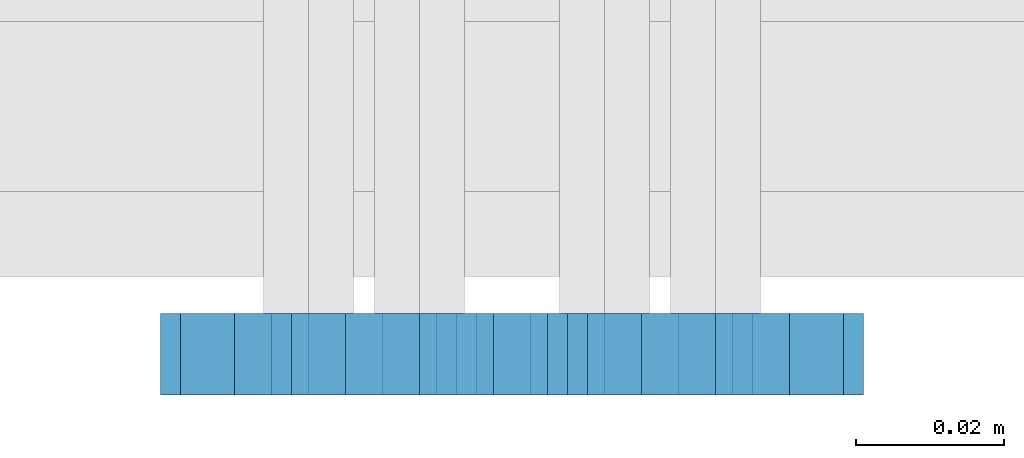
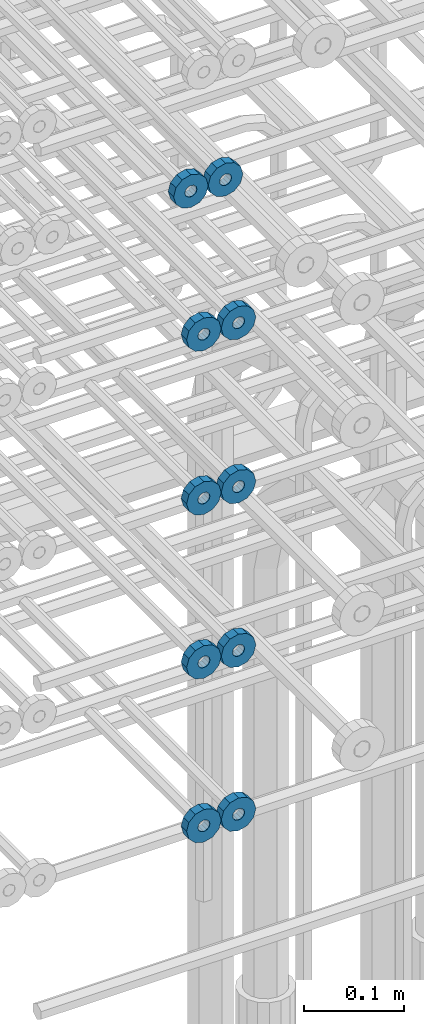
# One storey, part 168 of 177: 10 beams.
"""IFC2X3 building model written with IfcOpenShell, lengths in millimetres."""

from ifc_helpers import new_model, si_unit, frame, origin_with_axes, place, context, subcontext, project, spatial, faceted_brep, material, type_object, element, save


model = new_model("IFC2X3")

# Units and contexts
model_context_1 = context("Model", 3, precision=1e-05, world=origin_with_axes())
model_context_2 = context("Model", 3, precision=1e-05, world=origin_with_axes())
body_context = subcontext(model_context_2, "Body", "Model", "MODEL_VIEW")
ifc_project = project(units=[si_unit("LENGTHUNIT", "METRE", prefix="MILLI"), si_unit("AREAUNIT", "SQUARE_METRE"), si_unit("VOLUMEUNIT", "CUBIC_METRE"), si_unit("MASSUNIT", "GRAM", prefix="KILO"), si_unit("TIMEUNIT", "SECOND"), si_unit("PLANEANGLEUNIT", "RADIAN"), si_unit("SOLIDANGLEUNIT", "STERADIAN"), si_unit("THERMODYNAMICTEMPERATUREUNIT", "DEGREE_CELSIUS"), si_unit("LUMINOUSINTENSITYUNIT", "LUMEN")], contexts=[model_context_1])

# Site, building, storey
site_placement = place(None, origin_with_axes())
site = spatial("IfcSite", under=ifc_project, at=site_placement, CompositionType="ELEMENT")
building_placement = place(site_placement, origin_with_axes())
building = spatial("IfcBuilding", under=site, at=building_placement, Name="Undefined", CompositionType="ELEMENT")
storey_placement = place(building_placement, origin_with_axes())
storey = spatial("IfcBuildingStorey", under=building, at=storey_placement, Name="Undefined", CompositionType="ELEMENT", Elevation=0.0)

# Beams
ifc_material = material(Name="STEEL/Steel_Undefined")
beam_type = type_object("IfcBeamType", PredefinedType="NOTDEFINED")
beam_1_placement = place(storey_placement, frame((2036031.99847313, 6205070.98588033, 21004.9868114202), z_axis=(0.0, 0.0, -1.0), x_axis=(0.0, -1.0, 0.0)))
element("IfcBeam", 1, at=beam_1_placement, inside=storey, type_object=beam_type, material=ifc_material, context=body_context, shape_type="Brep", body=[
    faceted_brep([(-3.63797880709171e-12, -7.0, -2.3283064365387e-10), (-8.62348444298797e-13, -6.06217782649107, 3.5), (10.9999999999964, -6.06217782665044, 3.49999999976717), (10.9999999999964, -7.0, -2.3283064365387e-10), (-3.63797880709171e-12, -3.5, 6.06217782618478), (11.0, -3.5, 6.06217782618478), (-1.72469688859759e-12, 0.0, 7.0), (11.0, 0.0, 6.99999999976717), (-3.63797880709171e-12, 3.5, 6.06217782618478), (11.0, 3.5, 6.06217782618478), (-8.62348444298795e-13, 6.06217782649107, 3.5), (10.9999999999964, 6.06217782665044, 3.49999999976717), (-3.63797880709171e-12, 7.0, -2.3283064365387e-10), (10.9999999999964, 7.0, -2.3283064365387e-10), (8.62348444298797e-13, 6.06217782649107, -3.5), (10.9999999999964, 6.06217782665044, -3.50000000023283), (-3.63797880709171e-12, 3.5, -6.06217782665044), (10.9999999999964, 3.5, -6.06217782665044), (1.72469688859759e-12, -2.72004641033163e-15, -7.0), (10.9999999999964, 0.0, -7.00000000023283), (-3.63797880709171e-12, -3.5, -6.06217782665044), (10.9999999999964, -3.5, -6.06217782665044), (8.62348444298796e-13, -6.06217782649107, -3.5), (10.9999999999964, -6.06217782665044, -3.50000000023283), (0.0, -20.0000000009313, 0.0), (0.0, -17.320508075878, -10.0), (10.9999999999964, -17.320508075878, -10.0000000002328), (10.9999999999964, -20.0, -2.3283064365387e-10), (0.0, -10.0000000009313, -17.3205080756452), (11.0, -10.0, -17.320508075878), (0.0, -1.86264514923096e-09, -19.9999999998836), (10.9999999999964, 0.0, -20.0000000002328), (0.0, 9.99999999906868, -17.3205080755288), (11.0, 10.0, -17.320508075878), (0.0, 17.320508075878, -10.0), (10.9999999999964, 17.320508075878, -10.0000000002328), (0.0, 19.9999999990687, 0.0), (10.9999999999964, 20.0, -2.3283064365387e-10), (0.0, 17.3205080740154, 10.0), (11.0, 17.320508075878, 9.99999999976717), (0.0, 9.99999999906868, 17.3205080757616), (10.9999999999964, 10.0, 17.3205080754124), (0.0, 0.0, 20.0000000001164), (10.9999999999964, 0.0, 19.9999999997672), (0.0, -10.0000000009313, 17.3205080757616), (10.9999999999964, -10.0, 17.3205080754124), (0.0, -17.3205080777407, 10.0000000001164), (11.0, -17.320508075878, 9.99999999976717)], [[[0, 1, 2, 3]], [[1, 4, 5, 2]], [[4, 6, 7, 5]], [[6, 8, 9, 7]], [[8, 10, 11, 9]], [[10, 12, 13, 11]], [[12, 14, 15, 13]], [[14, 16, 17, 15]], [[16, 18, 19, 17]], [[18, 20, 21, 19]], [[20, 22, 23, 21]], [[22, 0, 3, 23]], [[24, 25, 26, 27]], [[25, 28, 29, 26]], [[28, 30, 31, 29]], [[30, 32, 33, 31]], [[32, 34, 35, 33]], [[34, 36, 37, 35]], [[36, 38, 39, 37]], [[38, 40, 41, 39]], [[40, 42, 43, 41]], [[42, 44, 45, 43]], [[44, 46, 47, 45]], [[46, 24, 27, 47]], [[29, 31, 33, 35, 37, 39, 41, 43, 45, 47, 27, 26], [5, 7, 9, 11, 13, 15, 17, 19, 21, 23, 3, 2]], [[46, 44, 42, 40, 38, 36, 34, 32, 30, 28, 25, 24], [22, 20, 18, 16, 14, 12, 10, 8, 6, 4, 1, 0]]]),
])
beam_2_placement = place(storey_placement, frame((2035991.99847313, 6205070.98588033, 21004.9868114202), z_axis=(0.0, 0.0, -1.0), x_axis=(0.0, -1.0, 0.0)))
element("IfcBeam", 2, at=beam_2_placement, inside=storey, type_object=beam_type, material=ifc_material, context=body_context, shape_type="Brep", body=[
    faceted_brep([(-3.63797880709171e-12, -7.0, -2.3283064365387e-10), (-8.62348444298797e-13, -6.06217782649107, 3.5), (10.9999999999964, -6.06217782665044, 3.49999999976717), (10.9999999999964, -7.0, -2.3283064365387e-10), (-3.63797880709171e-12, -3.5, 6.06217782618478), (11.0, -3.5, 6.06217782618478), (-1.72469688859759e-12, 0.0, 7.0), (11.0, 0.0, 6.99999999976717), (-3.63797880709171e-12, 3.5, 6.06217782618478), (11.0, 3.5, 6.06217782618478), (-8.62348444298795e-13, 6.06217782649107, 3.5), (10.9999999999964, 6.06217782665044, 3.49999999976717), (-3.63797880709171e-12, 7.0, -2.3283064365387e-10), (10.9999999999964, 7.0, -2.3283064365387e-10), (8.62348444298797e-13, 6.06217782649107, -3.5), (10.9999999999964, 6.06217782665044, -3.50000000023283), (-3.63797880709171e-12, 3.5, -6.06217782665044), (10.9999999999964, 3.5, -6.06217782665044), (1.72469688859759e-12, -2.72004641033163e-15, -7.0), (10.9999999999964, 0.0, -7.00000000023283), (-3.63797880709171e-12, -3.5, -6.06217782665044), (10.9999999999964, -3.5, -6.06217782665044), (8.62348444298796e-13, -6.06217782649107, -3.5), (10.9999999999964, -6.06217782665044, -3.50000000023283), (0.0, -20.0000000009313, 0.0), (0.0, -17.320508075878, -10.0), (10.9999999999964, -17.320508075878, -10.0000000002328), (10.9999999999964, -20.0, -2.3283064365387e-10), (0.0, -10.0000000009313, -17.3205080756452), (11.0, -10.0, -17.320508075878), (0.0, -1.86264514923096e-09, -19.9999999998836), (10.9999999999964, 0.0, -20.0000000002328), (0.0, 9.99999999906868, -17.3205080755288), (11.0, 10.0, -17.320508075878), (0.0, 17.320508075878, -10.0), (10.9999999999964, 17.320508075878, -10.0000000002328), (0.0, 19.9999999990687, 0.0), (10.9999999999964, 20.0, -2.3283064365387e-10), (0.0, 17.3205080740154, 10.0), (11.0, 17.320508075878, 9.99999999976717), (0.0, 9.99999999906868, 17.3205080757616), (10.9999999999964, 10.0, 17.3205080754124), (0.0, 0.0, 20.0000000001164), (10.9999999999964, 0.0, 19.9999999997672), (0.0, -10.0000000009313, 17.3205080757616), (10.9999999999964, -10.0, 17.3205080754124), (0.0, -17.3205080777407, 10.0000000001164), (11.0, -17.320508075878, 9.99999999976717)], [[[0, 1, 2, 3]], [[1, 4, 5, 2]], [[4, 6, 7, 5]], [[6, 8, 9, 7]], [[8, 10, 11, 9]], [[10, 12, 13, 11]], [[12, 14, 15, 13]], [[14, 16, 17, 15]], [[16, 18, 19, 17]], [[18, 20, 21, 19]], [[20, 22, 23, 21]], [[22, 0, 3, 23]], [[24, 25, 26, 27]], [[25, 28, 29, 26]], [[28, 30, 31, 29]], [[30, 32, 33, 31]], [[32, 34, 35, 33]], [[34, 36, 37, 35]], [[36, 38, 39, 37]], [[38, 40, 41, 39]], [[40, 42, 43, 41]], [[42, 44, 45, 43]], [[44, 46, 47, 45]], [[46, 24, 27, 47]], [[29, 31, 33, 35, 37, 39, 41, 43, 45, 47, 27, 26], [5, 7, 9, 11, 13, 15, 17, 19, 21, 23, 3, 2]], [[46, 44, 42, 40, 38, 36, 34, 32, 30, 28, 25, 24], [22, 20, 18, 16, 14, 12, 10, 8, 6, 4, 1, 0]]]),
])
beam_3_placement = place(storey_placement, frame((2036046.99847313, 6205070.98588033, 20824.9868114254), z_axis=(0.0, 0.0, -1.0), x_axis=(0.0, -1.0, 0.0)))
element("IfcBeam", 3, at=beam_3_placement, inside=storey, type_object=beam_type, material=ifc_material, context=body_context, shape_type="Brep", body=[
    faceted_brep([(-3.63797880709171e-12, -7.0, -2.3283064365387e-10), (-8.62348444298797e-13, -6.06217782649107, 3.5), (10.9999999999964, -6.06217782665044, 3.49999999976717), (10.9999999999964, -7.0, -2.3283064365387e-10), (-3.63797880709171e-12, -3.5, 6.06217782618478), (11.0, -3.5, 6.06217782618478), (-1.72469688859759e-12, 0.0, 7.0), (11.0, 0.0, 6.99999999976717), (-3.63797880709171e-12, 3.5, 6.06217782618478), (11.0, 3.5, 6.06217782618478), (-8.62348444298795e-13, 6.06217782649107, 3.5), (10.9999999999964, 6.06217782665044, 3.49999999976717), (-3.63797880709171e-12, 7.0, -2.3283064365387e-10), (10.9999999999964, 7.0, -2.3283064365387e-10), (8.62348444298797e-13, 6.06217782649107, -3.5), (10.9999999999964, 6.06217782665044, -3.50000000023283), (-3.63797880709171e-12, 3.5, -6.06217782665044), (10.9999999999964, 3.5, -6.06217782665044), (1.72469688859759e-12, -2.72004641033163e-15, -7.0), (10.9999999999964, 0.0, -7.00000000023283), (-3.63797880709171e-12, -3.5, -6.06217782665044), (10.9999999999964, -3.5, -6.06217782665044), (8.62348444298796e-13, -6.06217782649107, -3.5), (10.9999999999964, -6.06217782665044, -3.50000000023283), (0.0, -20.0000000009313, 0.0), (0.0, -17.320508075878, -10.0), (10.9999999999964, -17.320508075878, -10.0000000002328), (10.9999999999964, -20.0, -2.3283064365387e-10), (0.0, -10.0000000009313, -17.3205080756452), (11.0, -10.0, -17.320508075878), (0.0, -1.86264514923096e-09, -19.9999999998836), (10.9999999999964, 0.0, -20.0000000002328), (0.0, 9.99999999906868, -17.3205080755288), (11.0, 10.0, -17.320508075878), (0.0, 17.320508075878, -10.0), (10.9999999999964, 17.320508075878, -10.0000000002328), (0.0, 19.9999999990687, 0.0), (10.9999999999964, 20.0, -2.3283064365387e-10), (0.0, 17.3205080740154, 10.0), (11.0, 17.320508075878, 9.99999999976717), (0.0, 9.99999999906868, 17.3205080757616), (10.9999999999964, 10.0, 17.3205080754124), (0.0, 0.0, 20.0000000001164), (10.9999999999964, 0.0, 19.9999999997672), (0.0, -10.0000000009313, 17.3205080757616), (10.9999999999964, -10.0, 17.3205080754124), (0.0, -17.3205080777407, 10.0000000001164), (11.0, -17.320508075878, 9.99999999976717)], [[[0, 1, 2, 3]], [[1, 4, 5, 2]], [[4, 6, 7, 5]], [[6, 8, 9, 7]], [[8, 10, 11, 9]], [[10, 12, 13, 11]], [[12, 14, 15, 13]], [[14, 16, 17, 15]], [[16, 18, 19, 17]], [[18, 20, 21, 19]], [[20, 22, 23, 21]], [[22, 0, 3, 23]], [[24, 25, 26, 27]], [[25, 28, 29, 26]], [[28, 30, 31, 29]], [[30, 32, 33, 31]], [[32, 34, 35, 33]], [[34, 36, 37, 35]], [[36, 38, 39, 37]], [[38, 40, 41, 39]], [[40, 42, 43, 41]], [[42, 44, 45, 43]], [[44, 46, 47, 45]], [[46, 24, 27, 47]], [[29, 31, 33, 35, 37, 39, 41, 43, 45, 47, 27, 26], [5, 7, 9, 11, 13, 15, 17, 19, 21, 23, 3, 2]], [[46, 44, 42, 40, 38, 36, 34, 32, 30, 28, 25, 24], [22, 20, 18, 16, 14, 12, 10, 8, 6, 4, 1, 0]]]),
])
beam_4_placement = place(storey_placement, frame((2036006.99847313, 6205070.98588033, 20824.9868114254), z_axis=(0.0, 0.0, -1.0), x_axis=(0.0, -1.0, 0.0)))
element("IfcBeam", 4, at=beam_4_placement, inside=storey, type_object=beam_type, material=ifc_material, context=body_context, shape_type="Brep", body=[
    faceted_brep([(-3.63797880709171e-12, -7.0, -2.3283064365387e-10), (-8.62348444298797e-13, -6.06217782649107, 3.5), (10.9999999999964, -6.06217782665044, 3.49999999976717), (10.9999999999964, -7.0, -2.3283064365387e-10), (-3.63797880709171e-12, -3.5, 6.06217782618478), (11.0, -3.5, 6.06217782618478), (-1.72469688859759e-12, 0.0, 7.0), (11.0, 0.0, 6.99999999976717), (-3.63797880709171e-12, 3.5, 6.06217782618478), (11.0, 3.5, 6.06217782618478), (-8.62348444298795e-13, 6.06217782649107, 3.5), (10.9999999999964, 6.06217782665044, 3.49999999976717), (-3.63797880709171e-12, 7.0, -2.3283064365387e-10), (10.9999999999964, 7.0, -2.3283064365387e-10), (8.62348444298797e-13, 6.06217782649107, -3.5), (10.9999999999964, 6.06217782665044, -3.50000000023283), (-3.63797880709171e-12, 3.5, -6.06217782665044), (10.9999999999964, 3.5, -6.06217782665044), (1.72469688859759e-12, -2.72004641033163e-15, -7.0), (10.9999999999964, 0.0, -7.00000000023283), (-3.63797880709171e-12, -3.5, -6.06217782665044), (10.9999999999964, -3.5, -6.06217782665044), (8.62348444298796e-13, -6.06217782649107, -3.5), (10.9999999999964, -6.06217782665044, -3.50000000023283), (0.0, -20.0000000009313, 0.0), (0.0, -17.320508075878, -10.0), (10.9999999999964, -17.320508075878, -10.0000000002328), (10.9999999999964, -20.0, -2.3283064365387e-10), (0.0, -10.0000000009313, -17.3205080756452), (11.0, -10.0, -17.320508075878), (0.0, -1.86264514923096e-09, -19.9999999998836), (10.9999999999964, 0.0, -20.0000000002328), (0.0, 9.99999999906868, -17.3205080755288), (11.0, 10.0, -17.320508075878), (0.0, 17.320508075878, -10.0), (10.9999999999964, 17.320508075878, -10.0000000002328), (0.0, 19.9999999990687, 0.0), (10.9999999999964, 20.0, -2.3283064365387e-10), (0.0, 17.3205080740154, 10.0), (11.0, 17.320508075878, 9.99999999976717), (0.0, 9.99999999906868, 17.3205080757616), (10.9999999999964, 10.0, 17.3205080754124), (0.0, 0.0, 20.0000000001164), (10.9999999999964, 0.0, 19.9999999997672), (0.0, -10.0000000009313, 17.3205080757616), (10.9999999999964, -10.0, 17.3205080754124), (0.0, -17.3205080777407, 10.0000000001164), (11.0, -17.320508075878, 9.99999999976717)], [[[0, 1, 2, 3]], [[1, 4, 5, 2]], [[4, 6, 7, 5]], [[6, 8, 9, 7]], [[8, 10, 11, 9]], [[10, 12, 13, 11]], [[12, 14, 15, 13]], [[14, 16, 17, 15]], [[16, 18, 19, 17]], [[18, 20, 21, 19]], [[20, 22, 23, 21]], [[22, 0, 3, 23]], [[24, 25, 26, 27]], [[25, 28, 29, 26]], [[28, 30, 31, 29]], [[30, 32, 33, 31]], [[32, 34, 35, 33]], [[34, 36, 37, 35]], [[36, 38, 39, 37]], [[38, 40, 41, 39]], [[40, 42, 43, 41]], [[42, 44, 45, 43]], [[44, 46, 47, 45]], [[46, 24, 27, 47]], [[29, 31, 33, 35, 37, 39, 41, 43, 45, 47, 27, 26], [5, 7, 9, 11, 13, 15, 17, 19, 21, 23, 3, 2]], [[46, 44, 42, 40, 38, 36, 34, 32, 30, 28, 25, 24], [22, 20, 18, 16, 14, 12, 10, 8, 6, 4, 1, 0]]]),
])
beam_5_placement = place(storey_placement, frame((2036046.99847313, 6205070.98588033, 20624.9868114254), z_axis=(0.0, 0.0, -1.0), x_axis=(0.0, -1.0, 0.0)))
element("IfcBeam", 5, at=beam_5_placement, inside=storey, type_object=beam_type, material=ifc_material, context=body_context, shape_type="Brep", body=[
    faceted_brep([(-3.63797880709171e-12, -7.0, -2.3283064365387e-10), (-8.62348444298797e-13, -6.06217782649107, 3.5), (10.9999999999964, -6.06217782665044, 3.49999999976717), (10.9999999999964, -7.0, -2.3283064365387e-10), (-3.63797880709171e-12, -3.5, 6.06217782618478), (11.0, -3.5, 6.06217782618478), (-1.72469688859759e-12, 0.0, 7.0), (11.0, 0.0, 6.99999999976717), (-3.63797880709171e-12, 3.5, 6.06217782618478), (11.0, 3.5, 6.06217782618478), (-8.62348444298795e-13, 6.06217782649107, 3.5), (10.9999999999964, 6.06217782665044, 3.49999999976717), (-3.63797880709171e-12, 7.0, -2.3283064365387e-10), (10.9999999999964, 7.0, -2.3283064365387e-10), (8.62348444298797e-13, 6.06217782649107, -3.5), (10.9999999999964, 6.06217782665044, -3.50000000023283), (-3.63797880709171e-12, 3.5, -6.06217782665044), (10.9999999999964, 3.5, -6.06217782665044), (1.72469688859759e-12, -2.72004641033163e-15, -7.0), (10.9999999999964, 0.0, -7.00000000023283), (-3.63797880709171e-12, -3.5, -6.06217782665044), (10.9999999999964, -3.5, -6.06217782665044), (8.62348444298796e-13, -6.06217782649107, -3.5), (10.9999999999964, -6.06217782665044, -3.50000000023283), (0.0, -20.0000000009313, 0.0), (0.0, -17.320508075878, -10.0), (10.9999999999964, -17.320508075878, -10.0000000002328), (10.9999999999964, -20.0, -2.3283064365387e-10), (0.0, -10.0000000009313, -17.3205080756452), (11.0, -10.0, -17.320508075878), (0.0, -1.86264514923096e-09, -19.9999999998836), (10.9999999999964, 0.0, -20.0000000002328), (0.0, 9.99999999906868, -17.3205080755288), (11.0, 10.0, -17.320508075878), (0.0, 17.320508075878, -10.0), (10.9999999999964, 17.320508075878, -10.0000000002328), (0.0, 19.9999999990687, 0.0), (10.9999999999964, 20.0, -2.3283064365387e-10), (0.0, 17.3205080740154, 10.0), (11.0, 17.320508075878, 9.99999999976717), (0.0, 9.99999999906868, 17.3205080757616), (10.9999999999964, 10.0, 17.3205080754124), (0.0, 0.0, 20.0000000001164), (10.9999999999964, 0.0, 19.9999999997672), (0.0, -10.0000000009313, 17.3205080757616), (10.9999999999964, -10.0, 17.3205080754124), (0.0, -17.3205080777407, 10.0000000001164), (11.0, -17.320508075878, 9.99999999976717)], [[[0, 1, 2, 3]], [[1, 4, 5, 2]], [[4, 6, 7, 5]], [[6, 8, 9, 7]], [[8, 10, 11, 9]], [[10, 12, 13, 11]], [[12, 14, 15, 13]], [[14, 16, 17, 15]], [[16, 18, 19, 17]], [[18, 20, 21, 19]], [[20, 22, 23, 21]], [[22, 0, 3, 23]], [[24, 25, 26, 27]], [[25, 28, 29, 26]], [[28, 30, 31, 29]], [[30, 32, 33, 31]], [[32, 34, 35, 33]], [[34, 36, 37, 35]], [[36, 38, 39, 37]], [[38, 40, 41, 39]], [[40, 42, 43, 41]], [[42, 44, 45, 43]], [[44, 46, 47, 45]], [[46, 24, 27, 47]], [[29, 31, 33, 35, 37, 39, 41, 43, 45, 47, 27, 26], [5, 7, 9, 11, 13, 15, 17, 19, 21, 23, 3, 2]], [[46, 44, 42, 40, 38, 36, 34, 32, 30, 28, 25, 24], [22, 20, 18, 16, 14, 12, 10, 8, 6, 4, 1, 0]]]),
])
beam_6_placement = place(storey_placement, frame((2036006.99847313, 6205070.98588033, 20624.9868114254), z_axis=(0.0, 0.0, -1.0), x_axis=(0.0, -1.0, 0.0)))
element("IfcBeam", 6, at=beam_6_placement, inside=storey, type_object=beam_type, material=ifc_material, context=body_context, shape_type="Brep", body=[
    faceted_brep([(-3.63797880709171e-12, -7.0, -2.3283064365387e-10), (-8.62348444298797e-13, -6.06217782649107, 3.5), (10.9999999999964, -6.06217782665044, 3.49999999976717), (10.9999999999964, -7.0, -2.3283064365387e-10), (-3.63797880709171e-12, -3.5, 6.06217782618478), (11.0, -3.5, 6.06217782618478), (-1.72469688859759e-12, 0.0, 7.0), (11.0, 0.0, 6.99999999976717), (-3.63797880709171e-12, 3.5, 6.06217782618478), (11.0, 3.5, 6.06217782618478), (-8.62348444298795e-13, 6.06217782649107, 3.5), (10.9999999999964, 6.06217782665044, 3.49999999976717), (-3.63797880709171e-12, 7.0, -2.3283064365387e-10), (10.9999999999964, 7.0, -2.3283064365387e-10), (8.62348444298797e-13, 6.06217782649107, -3.5), (10.9999999999964, 6.06217782665044, -3.50000000023283), (-3.63797880709171e-12, 3.5, -6.06217782665044), (10.9999999999964, 3.5, -6.06217782665044), (1.72469688859759e-12, -2.72004641033163e-15, -7.0), (10.9999999999964, 0.0, -7.00000000023283), (-3.63797880709171e-12, -3.5, -6.06217782665044), (10.9999999999964, -3.5, -6.06217782665044), (8.62348444298796e-13, -6.06217782649107, -3.5), (10.9999999999964, -6.06217782665044, -3.50000000023283), (0.0, -20.0000000009313, 0.0), (0.0, -17.320508075878, -10.0), (10.9999999999964, -17.320508075878, -10.0000000002328), (10.9999999999964, -20.0, -2.3283064365387e-10), (0.0, -10.0000000009313, -17.3205080756452), (11.0, -10.0, -17.320508075878), (0.0, -1.86264514923096e-09, -19.9999999998836), (10.9999999999964, 0.0, -20.0000000002328), (0.0, 9.99999999906868, -17.3205080755288), (11.0, 10.0, -17.320508075878), (0.0, 17.320508075878, -10.0), (10.9999999999964, 17.320508075878, -10.0000000002328), (0.0, 19.9999999990687, 0.0), (10.9999999999964, 20.0, -2.3283064365387e-10), (0.0, 17.3205080740154, 10.0), (11.0, 17.320508075878, 9.99999999976717), (0.0, 9.99999999906868, 17.3205080757616), (10.9999999999964, 10.0, 17.3205080754124), (0.0, 0.0, 20.0000000001164), (10.9999999999964, 0.0, 19.9999999997672), (0.0, -10.0000000009313, 17.3205080757616), (10.9999999999964, -10.0, 17.3205080754124), (0.0, -17.3205080777407, 10.0000000001164), (11.0, -17.320508075878, 9.99999999976717)], [[[0, 1, 2, 3]], [[1, 4, 5, 2]], [[4, 6, 7, 5]], [[6, 8, 9, 7]], [[8, 10, 11, 9]], [[10, 12, 13, 11]], [[12, 14, 15, 13]], [[14, 16, 17, 15]], [[16, 18, 19, 17]], [[18, 20, 21, 19]], [[20, 22, 23, 21]], [[22, 0, 3, 23]], [[24, 25, 26, 27]], [[25, 28, 29, 26]], [[28, 30, 31, 29]], [[30, 32, 33, 31]], [[32, 34, 35, 33]], [[34, 36, 37, 35]], [[36, 38, 39, 37]], [[38, 40, 41, 39]], [[40, 42, 43, 41]], [[42, 44, 45, 43]], [[44, 46, 47, 45]], [[46, 24, 27, 47]], [[29, 31, 33, 35, 37, 39, 41, 43, 45, 47, 27, 26], [5, 7, 9, 11, 13, 15, 17, 19, 21, 23, 3, 2]], [[46, 44, 42, 40, 38, 36, 34, 32, 30, 28, 25, 24], [22, 20, 18, 16, 14, 12, 10, 8, 6, 4, 1, 0]]]),
])
beam_7_placement = place(storey_placement, frame((2036046.99847313, 6205070.98588034, 20424.9868114254), z_axis=(0.0, 0.0, -1.0), x_axis=(0.0, -1.0, 0.0)))
element("IfcBeam", 7, at=beam_7_placement, inside=storey, type_object=beam_type, material=ifc_material, context=body_context, shape_type="Brep", body=[
    faceted_brep([(-3.63797880709171e-12, -7.0, -2.3283064365387e-10), (-8.62348444298797e-13, -6.06217782649107, 3.5), (10.9999999999964, -6.06217782665044, 3.49999999976717), (10.9999999999964, -7.0, -2.3283064365387e-10), (-3.63797880709171e-12, -3.5, 6.06217782618478), (11.0, -3.5, 6.06217782618478), (-1.72469688859759e-12, 0.0, 7.0), (11.0, 0.0, 6.99999999976717), (-3.63797880709171e-12, 3.5, 6.06217782618478), (11.0, 3.5, 6.06217782618478), (-8.62348444298795e-13, 6.06217782649107, 3.5), (10.9999999999964, 6.06217782665044, 3.49999999976717), (-3.63797880709171e-12, 7.0, -2.3283064365387e-10), (10.9999999999964, 7.0, -2.3283064365387e-10), (8.62348444298797e-13, 6.06217782649107, -3.5), (10.9999999999964, 6.06217782665044, -3.50000000023283), (-3.63797880709171e-12, 3.5, -6.06217782665044), (10.9999999999964, 3.5, -6.06217782665044), (1.72469688859759e-12, -2.72004641033163e-15, -7.0), (10.9999999999964, 0.0, -7.00000000023283), (-3.63797880709171e-12, -3.5, -6.06217782665044), (10.9999999999964, -3.5, -6.06217782665044), (8.62348444298796e-13, -6.06217782649107, -3.5), (10.9999999999964, -6.06217782665044, -3.50000000023283), (0.0, -20.0000000009313, 0.0), (0.0, -17.320508075878, -10.0), (10.9999999999964, -17.320508075878, -10.0000000002328), (10.9999999999964, -20.0, -2.3283064365387e-10), (0.0, -10.0000000009313, -17.3205080756452), (11.0, -10.0, -17.320508075878), (0.0, -1.86264514923096e-09, -19.9999999998836), (10.9999999999964, 0.0, -20.0000000002328), (0.0, 9.99999999906868, -17.3205080755288), (11.0, 10.0, -17.320508075878), (0.0, 17.320508075878, -10.0), (10.9999999999964, 17.320508075878, -10.0000000002328), (0.0, 19.9999999990687, 0.0), (10.9999999999964, 20.0, -2.3283064365387e-10), (0.0, 17.3205080740154, 10.0), (11.0, 17.320508075878, 9.99999999976717), (0.0, 9.99999999906868, 17.3205080757616), (10.9999999999964, 10.0, 17.3205080754124), (0.0, 0.0, 20.0000000001164), (10.9999999999964, 0.0, 19.9999999997672), (0.0, -10.0000000009313, 17.3205080757616), (10.9999999999964, -10.0, 17.3205080754124), (0.0, -17.3205080777407, 10.0000000001164), (11.0, -17.320508075878, 9.99999999976717)], [[[0, 1, 2, 3]], [[1, 4, 5, 2]], [[4, 6, 7, 5]], [[6, 8, 9, 7]], [[8, 10, 11, 9]], [[10, 12, 13, 11]], [[12, 14, 15, 13]], [[14, 16, 17, 15]], [[16, 18, 19, 17]], [[18, 20, 21, 19]], [[20, 22, 23, 21]], [[22, 0, 3, 23]], [[24, 25, 26, 27]], [[25, 28, 29, 26]], [[28, 30, 31, 29]], [[30, 32, 33, 31]], [[32, 34, 35, 33]], [[34, 36, 37, 35]], [[36, 38, 39, 37]], [[38, 40, 41, 39]], [[40, 42, 43, 41]], [[42, 44, 45, 43]], [[44, 46, 47, 45]], [[46, 24, 27, 47]], [[29, 31, 33, 35, 37, 39, 41, 43, 45, 47, 27, 26], [5, 7, 9, 11, 13, 15, 17, 19, 21, 23, 3, 2]], [[46, 44, 42, 40, 38, 36, 34, 32, 30, 28, 25, 24], [22, 20, 18, 16, 14, 12, 10, 8, 6, 4, 1, 0]]]),
])
beam_8_placement = place(storey_placement, frame((2036006.99847313, 6205070.98588034, 20424.9868114254), z_axis=(0.0, 0.0, -1.0), x_axis=(0.0, -1.0, 0.0)))
element("IfcBeam", 8, at=beam_8_placement, inside=storey, type_object=beam_type, material=ifc_material, context=body_context, shape_type="Brep", body=[
    faceted_brep([(-3.63797880709171e-12, -7.0, -2.3283064365387e-10), (-8.62348444298797e-13, -6.06217782649107, 3.5), (10.9999999999964, -6.06217782665044, 3.49999999976717), (10.9999999999964, -7.0, -2.3283064365387e-10), (-3.63797880709171e-12, -3.5, 6.06217782618478), (11.0, -3.5, 6.06217782618478), (-1.72469688859759e-12, 0.0, 7.0), (11.0, 0.0, 6.99999999976717), (-3.63797880709171e-12, 3.5, 6.06217782618478), (11.0, 3.5, 6.06217782618478), (-8.62348444298795e-13, 6.06217782649107, 3.5), (10.9999999999964, 6.06217782665044, 3.49999999976717), (-3.63797880709171e-12, 7.0, -2.3283064365387e-10), (10.9999999999964, 7.0, -2.3283064365387e-10), (8.62348444298797e-13, 6.06217782649107, -3.5), (10.9999999999964, 6.06217782665044, -3.50000000023283), (-3.63797880709171e-12, 3.5, -6.06217782665044), (10.9999999999964, 3.5, -6.06217782665044), (1.72469688859759e-12, -2.72004641033163e-15, -7.0), (10.9999999999964, 0.0, -7.00000000023283), (-3.63797880709171e-12, -3.5, -6.06217782665044), (10.9999999999964, -3.5, -6.06217782665044), (8.62348444298796e-13, -6.06217782649107, -3.5), (10.9999999999964, -6.06217782665044, -3.50000000023283), (0.0, -20.0000000009313, 0.0), (0.0, -17.320508075878, -10.0), (10.9999999999964, -17.320508075878, -10.0000000002328), (10.9999999999964, -20.0, -2.3283064365387e-10), (0.0, -10.0000000009313, -17.3205080756452), (11.0, -10.0, -17.320508075878), (0.0, -1.86264514923096e-09, -19.9999999998836), (10.9999999999964, 0.0, -20.0000000002328), (0.0, 9.99999999906868, -17.3205080755288), (11.0, 10.0, -17.320508075878), (0.0, 17.320508075878, -10.0), (10.9999999999964, 17.320508075878, -10.0000000002328), (0.0, 19.9999999990687, 0.0), (10.9999999999964, 20.0, -2.3283064365387e-10), (0.0, 17.3205080740154, 10.0), (11.0, 17.320508075878, 9.99999999976717), (0.0, 9.99999999906868, 17.3205080757616), (10.9999999999964, 10.0, 17.3205080754124), (0.0, 0.0, 20.0000000001164), (10.9999999999964, 0.0, 19.9999999997672), (0.0, -10.0000000009313, 17.3205080757616), (10.9999999999964, -10.0, 17.3205080754124), (0.0, -17.3205080777407, 10.0000000001164), (11.0, -17.320508075878, 9.99999999976717)], [[[0, 1, 2, 3]], [[1, 4, 5, 2]], [[4, 6, 7, 5]], [[6, 8, 9, 7]], [[8, 10, 11, 9]], [[10, 12, 13, 11]], [[12, 14, 15, 13]], [[14, 16, 17, 15]], [[16, 18, 19, 17]], [[18, 20, 21, 19]], [[20, 22, 23, 21]], [[22, 0, 3, 23]], [[24, 25, 26, 27]], [[25, 28, 29, 26]], [[28, 30, 31, 29]], [[30, 32, 33, 31]], [[32, 34, 35, 33]], [[34, 36, 37, 35]], [[36, 38, 39, 37]], [[38, 40, 41, 39]], [[40, 42, 43, 41]], [[42, 44, 45, 43]], [[44, 46, 47, 45]], [[46, 24, 27, 47]], [[29, 31, 33, 35, 37, 39, 41, 43, 45, 47, 27, 26], [5, 7, 9, 11, 13, 15, 17, 19, 21, 23, 3, 2]], [[46, 44, 42, 40, 38, 36, 34, 32, 30, 28, 25, 24], [22, 20, 18, 16, 14, 12, 10, 8, 6, 4, 1, 0]]]),
])
beam_9_placement = place(storey_placement, frame((2036006.99847313, 6205070.98588034, 20224.9868114254), z_axis=(0.0, 0.0, -1.0), x_axis=(0.0, -1.0, 0.0)))
element("IfcBeam", 9, at=beam_9_placement, inside=storey, type_object=beam_type, material=ifc_material, context=body_context, shape_type="Brep", body=[
    faceted_brep([(-3.63797880709171e-12, -7.0, -2.3283064365387e-10), (-8.62348444298797e-13, -6.06217782649107, 3.5), (10.9999999999964, -6.06217782665044, 3.49999999976717), (10.9999999999964, -7.0, -2.3283064365387e-10), (-3.63797880709171e-12, -3.5, 6.06217782618478), (11.0, -3.5, 6.06217782618478), (-1.72469688859759e-12, 0.0, 7.0), (11.0, 0.0, 6.99999999976717), (-3.63797880709171e-12, 3.5, 6.06217782618478), (11.0, 3.5, 6.06217782618478), (-8.62348444298795e-13, 6.06217782649107, 3.5), (10.9999999999964, 6.06217782665044, 3.49999999976717), (-3.63797880709171e-12, 7.0, -2.3283064365387e-10), (10.9999999999964, 7.0, -2.3283064365387e-10), (8.62348444298797e-13, 6.06217782649107, -3.5), (10.9999999999964, 6.06217782665044, -3.50000000023283), (-3.63797880709171e-12, 3.5, -6.06217782665044), (10.9999999999964, 3.5, -6.06217782665044), (1.72469688859759e-12, -2.72004641033163e-15, -7.0), (10.9999999999964, 0.0, -7.00000000023283), (-3.63797880709171e-12, -3.5, -6.06217782665044), (10.9999999999964, -3.5, -6.06217782665044), (8.62348444298796e-13, -6.06217782649107, -3.5), (10.9999999999964, -6.06217782665044, -3.50000000023283), (0.0, -20.0000000009313, 0.0), (0.0, -17.320508075878, -10.0), (10.9999999999964, -17.320508075878, -10.0000000002328), (10.9999999999964, -20.0, -2.3283064365387e-10), (0.0, -10.0000000009313, -17.3205080756452), (11.0, -10.0, -17.320508075878), (0.0, -1.86264514923096e-09, -19.9999999998836), (10.9999999999964, 0.0, -20.0000000002328), (0.0, 9.99999999906868, -17.3205080755288), (11.0, 10.0, -17.320508075878), (0.0, 17.320508075878, -10.0), (10.9999999999964, 17.320508075878, -10.0000000002328), (0.0, 19.9999999990687, 0.0), (10.9999999999964, 20.0, -2.3283064365387e-10), (0.0, 17.3205080740154, 10.0), (11.0, 17.320508075878, 9.99999999976717), (0.0, 9.99999999906868, 17.3205080757616), (10.9999999999964, 10.0, 17.3205080754124), (0.0, 0.0, 20.0000000001164), (10.9999999999964, 0.0, 19.9999999997672), (0.0, -10.0000000009313, 17.3205080757616), (10.9999999999964, -10.0, 17.3205080754124), (0.0, -17.3205080777407, 10.0000000001164), (11.0, -17.320508075878, 9.99999999976717)], [[[0, 1, 2, 3]], [[1, 4, 5, 2]], [[4, 6, 7, 5]], [[6, 8, 9, 7]], [[8, 10, 11, 9]], [[10, 12, 13, 11]], [[12, 14, 15, 13]], [[14, 16, 17, 15]], [[16, 18, 19, 17]], [[18, 20, 21, 19]], [[20, 22, 23, 21]], [[22, 0, 3, 23]], [[24, 25, 26, 27]], [[25, 28, 29, 26]], [[28, 30, 31, 29]], [[30, 32, 33, 31]], [[32, 34, 35, 33]], [[34, 36, 37, 35]], [[36, 38, 39, 37]], [[38, 40, 41, 39]], [[40, 42, 43, 41]], [[42, 44, 45, 43]], [[44, 46, 47, 45]], [[46, 24, 27, 47]], [[29, 31, 33, 35, 37, 39, 41, 43, 45, 47, 27, 26], [5, 7, 9, 11, 13, 15, 17, 19, 21, 23, 3, 2]], [[46, 44, 42, 40, 38, 36, 34, 32, 30, 28, 25, 24], [22, 20, 18, 16, 14, 12, 10, 8, 6, 4, 1, 0]]]),
])
beam_10_placement = place(storey_placement, frame((2036046.99847313, 6205070.98588034, 20224.9868114254), z_axis=(0.0, 0.0, -1.0), x_axis=(0.0, -1.0, 0.0)))
element("IfcBeam", 10, at=beam_10_placement, inside=storey, type_object=beam_type, material=ifc_material, context=body_context, shape_type="Brep", body=[
    faceted_brep([(-3.63797880709171e-12, -7.0, -2.3283064365387e-10), (-8.62348444298797e-13, -6.06217782649107, 3.5), (10.9999999999964, -6.06217782665044, 3.49999999976717), (10.9999999999964, -7.0, -2.3283064365387e-10), (-3.63797880709171e-12, -3.5, 6.06217782618478), (11.0, -3.5, 6.06217782618478), (-1.72469688859759e-12, 0.0, 7.0), (11.0, 0.0, 6.99999999976717), (-3.63797880709171e-12, 3.5, 6.06217782618478), (11.0, 3.5, 6.06217782618478), (-8.62348444298795e-13, 6.06217782649107, 3.5), (10.9999999999964, 6.06217782665044, 3.49999999976717), (-3.63797880709171e-12, 7.0, -2.3283064365387e-10), (10.9999999999964, 7.0, -2.3283064365387e-10), (8.62348444298797e-13, 6.06217782649107, -3.5), (10.9999999999964, 6.06217782665044, -3.50000000023283), (-3.63797880709171e-12, 3.5, -6.06217782665044), (10.9999999999964, 3.5, -6.06217782665044), (1.72469688859759e-12, -2.72004641033163e-15, -7.0), (10.9999999999964, 0.0, -7.00000000023283), (-3.63797880709171e-12, -3.5, -6.06217782665044), (10.9999999999964, -3.5, -6.06217782665044), (8.62348444298796e-13, -6.06217782649107, -3.5), (10.9999999999964, -6.06217782665044, -3.50000000023283), (0.0, -20.0000000009313, 0.0), (0.0, -17.320508075878, -10.0), (10.9999999999964, -17.320508075878, -10.0000000002328), (10.9999999999964, -20.0, -2.3283064365387e-10), (0.0, -10.0000000009313, -17.3205080756452), (11.0, -10.0, -17.320508075878), (0.0, -1.86264514923096e-09, -19.9999999998836), (10.9999999999964, 0.0, -20.0000000002328), (0.0, 9.99999999906868, -17.3205080755288), (11.0, 10.0, -17.320508075878), (0.0, 17.320508075878, -10.0), (10.9999999999964, 17.320508075878, -10.0000000002328), (0.0, 19.9999999990687, 0.0), (10.9999999999964, 20.0, -2.3283064365387e-10), (0.0, 17.3205080740154, 10.0), (11.0, 17.320508075878, 9.99999999976717), (0.0, 9.99999999906868, 17.3205080757616), (10.9999999999964, 10.0, 17.3205080754124), (0.0, 0.0, 20.0000000001164), (10.9999999999964, 0.0, 19.9999999997672), (0.0, -10.0000000009313, 17.3205080757616), (10.9999999999964, -10.0, 17.3205080754124), (0.0, -17.3205080777407, 10.0000000001164), (11.0, -17.320508075878, 9.99999999976717)], [[[0, 1, 2, 3]], [[1, 4, 5, 2]], [[4, 6, 7, 5]], [[6, 8, 9, 7]], [[8, 10, 11, 9]], [[10, 12, 13, 11]], [[12, 14, 15, 13]], [[14, 16, 17, 15]], [[16, 18, 19, 17]], [[18, 20, 21, 19]], [[20, 22, 23, 21]], [[22, 0, 3, 23]], [[24, 25, 26, 27]], [[25, 28, 29, 26]], [[28, 30, 31, 29]], [[30, 32, 33, 31]], [[32, 34, 35, 33]], [[34, 36, 37, 35]], [[36, 38, 39, 37]], [[38, 40, 41, 39]], [[40, 42, 43, 41]], [[42, 44, 45, 43]], [[44, 46, 47, 45]], [[46, 24, 27, 47]], [[29, 31, 33, 35, 37, 39, 41, 43, 45, 47, 27, 26], [5, 7, 9, 11, 13, 15, 17, 19, 21, 23, 3, 2]], [[46, 44, 42, 40, 38, 36, 34, 32, 30, 28, 25, 24], [22, 20, 18, 16, 14, 12, 10, 8, 6, 4, 1, 0]]]),
])

save(model, "model.ifc")
